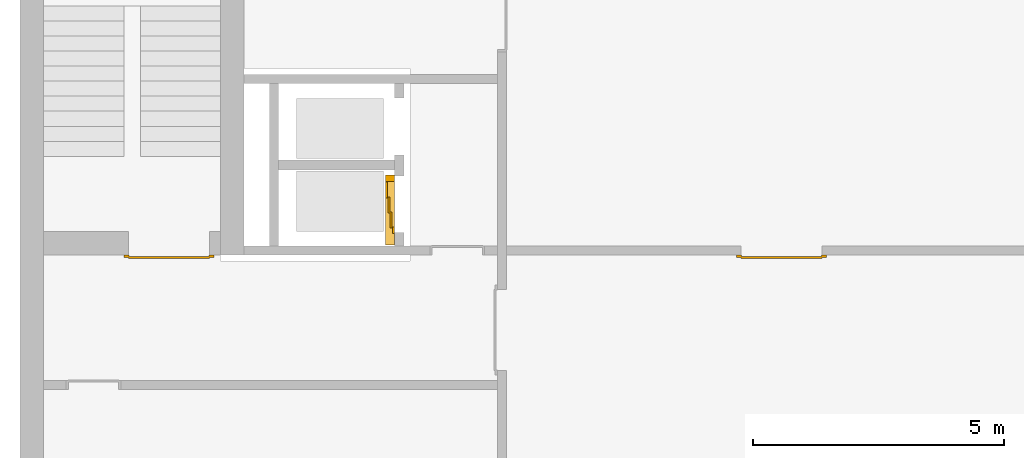
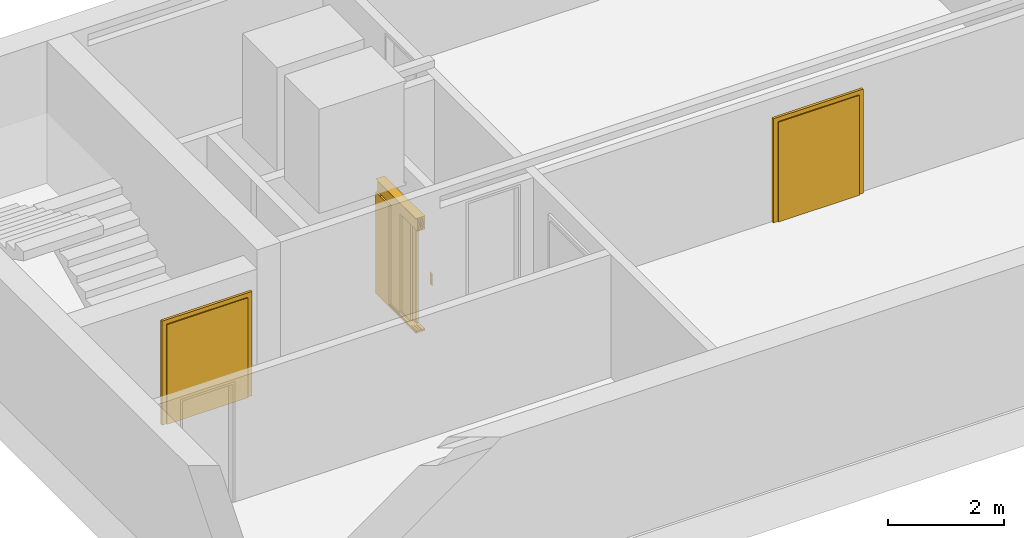
# One storey, part 4 of 5: 3 doors.
"""IFC4 building model written with IfcOpenShell, lengths in metres."""

import ifcopenshell
import ifcopenshell.guid

model = None  # the IFC model being written
_history = None  # IfcOwnerHistory: only IFC2X3 demands one
_inside = {}  # id of a spatial element -> (the spatial element, [elements in it])
_under = {}  # id of a project, library or spatial element -> (it, [spatial elements below it])
_declared = {}  # id of a project -> (the project, [libraries it declares])
_typed = {}  # id of a type object -> (the type object, [elements of that type])
_made_of = {}  # id of a material, layer set ... -> (it, [elements and type objects made of it])


def new_model(schema):
    """Start an empty IFC model of exactly this schema.

    Asked for "IFC4X3", IfcOpenShell would pick the latest addendum, in which some entities
    have other attributes; the version numbers below select the first issue.
    IFC2X3 requires an IfcOwnerHistory on every rooted entity: one is made here for all.
    """
    global model, _history
    if schema == "IFC4X3":
        model = ifcopenshell.file(schema_version=(4, 3, 0, 0))
    else:
        model = ifcopenshell.file(schema=schema)
    _inside.clear()
    _under.clear()
    _declared.clear()
    _typed.clear()
    _made_of.clear()
    _history = None
    if model.schema == "IFC2X3":
        org = make("IfcOrganization", Name="unknown")
        user = make(
            "IfcPersonAndOrganization",
            ThePerson=make("IfcPerson", FamilyName="unknown"),
            TheOrganization=org,
        )
        app = make(
            "IfcApplication",
            ApplicationDeveloper=org,
            Version="unknown",
            ApplicationFullName="unknown",
            ApplicationIdentifier="unknown",
        )
        _history = make(
            "IfcOwnerHistory",
            OwningUser=user,
            OwningApplication=app,
            ChangeAction="ADDED",
            CreationDate=0,
        )
    return model


def make(cls, **values):
    """One entity of the class cls with the attributes given. An attribute that is None is left unset."""
    return model.create_entity(
        cls, **{name: value for name, value in values.items() if value is not None}
    )


def entity(cls, *values):
    """Any entity or typed value of the class cls, its attributes in the order of the schema. None: left unset."""
    e = model.create_entity(cls)
    for i, value in enumerate(values):
        if value is not None:
            e[i] = value
    return e


def rooted(cls, **values):
    """An entity with a GlobalId (a new one), such as an element, a storey or a relation."""
    return make(cls, GlobalId=ifcopenshell.guid.new(), OwnerHistory=_history, **values)


def si_unit(unit_type, name, prefix=None):
    """IfcSIUnit, for example si_unit("LENGTHUNIT", "METRE", prefix="MILLI")."""
    return make("IfcSIUnit", UnitType=unit_type, Prefix=prefix, Name=name)


def converted_unit(unit_type, name, factor, base, dimensions=None, offset=None):
    """IfcConversionBasedUnit, such as the inch: factor (a typed value) times the base unit."""
    return make(
        "IfcConversionBasedUnit"
        if offset is None
        else "IfcConversionBasedUnitWithOffset",
        ConversionOffset=offset,
        Dimensions=None
        if dimensions is None
        else entity("IfcDimensionalExponents", *dimensions),
        UnitType=unit_type,
        Name=name,
        ConversionFactor=make(
            "IfcMeasureWithUnit", ValueComponent=factor, UnitComponent=base
        ),
    )


def derived_unit(unit_type, elements):
    """IfcDerivedUnit: a product of units, each with its exponent."""
    return make(
        "IfcDerivedUnit",
        Elements=[
            make("IfcDerivedUnitElement", Unit=unit, Exponent=power)
            for unit, power in elements
        ],
        UnitType=unit_type,
    )


def assignment(units):
    """IfcUnitAssignment: the units of a project."""
    return None if units is None else make("IfcUnitAssignment", Units=units)


def point(xyz):
    """IfcCartesianPoint."""
    return None if xyz is None else make("IfcCartesianPoint", Coordinates=xyz)


def direction(xyz):
    """IfcDirection."""
    return None if xyz is None else make("IfcDirection", DirectionRatios=xyz)


def frame(location, z_axis=None, x_axis=None):
    """IfcAxis2Placement3D, a coordinate frame: its origin and axes. An axis left out is left unset."""
    return make(
        "IfcAxis2Placement3D",
        Location=point(location),
        Axis=direction(z_axis),
        RefDirection=direction(x_axis),
    )


def origin_with_axes():
    """The frame at (0, 0, 0) with the z axis (0, 0, 1) and the x axis (1, 0, 0) written out."""
    return frame((0.0, 0.0, 0.0), z_axis=(0.0, 0.0, 1.0), x_axis=(1.0, 0.0, 0.0))


def place(relative_to, where):
    """IfcLocalPlacement: puts the frame where relative to a parent placement (None: the world)."""
    return make(
        "IfcLocalPlacement", PlacementRelTo=relative_to, RelativePlacement=where
    )


def context(
    kind, dimensions, precision=None, world=None, true_north=None, identifier=None
):
    """IfcGeometricRepresentationContext, for example the 3D "Model" context."""
    return make(
        "IfcGeometricRepresentationContext",
        ContextIdentifier=identifier,
        ContextType=kind,
        CoordinateSpaceDimension=dimensions,
        Precision=precision,
        WorldCoordinateSystem=world,
        TrueNorth=true_north,
    )


def subcontext(parent, identifier, kind, view, scale=None):
    """IfcGeometricRepresentationSubContext, for example "Body" below "Model"."""
    return make(
        "IfcGeometricRepresentationSubContext",
        ContextIdentifier=identifier,
        ContextType=kind,
        ParentContext=parent,
        TargetScale=scale,
        TargetView=view,
    )


def project(units=None, contexts=None):
    """IfcProject with its units and contexts."""
    return rooted(
        "IfcProject",
        Name="project",
        RepresentationContexts=contexts,
        UnitsInContext=assignment(units),
    )


def spatial(cls, under=None, at=None, **own):
    """A site, building, storey or space (cls), placed at a placement, below another one or the project."""
    s = rooted(cls, ObjectPlacement=at, **own)
    if under is not None:
        _under.setdefault(under.id(), (under, []))[1].append(s)
    return s


def point_list(points):
    """IfcCartesianPointList2D or 3D."""
    cls = (
        "IfcCartesianPointList2D" if len(points[0]) == 2 else "IfcCartesianPointList3D"
    )
    return make(cls, CoordList=points)


def polygons(points, faces, closed=None, point_numbers=None):
    """IfcPolygonalFaceSet: a face is its outer loop, then its inner loops; points numbered from 1."""
    made = []
    for loops in faces:
        if len(loops) == 1:
            made.append(make("IfcIndexedPolygonalFace", CoordIndex=loops[0]))
        else:
            made.append(
                make(
                    "IfcIndexedPolygonalFaceWithVoids",
                    CoordIndex=loops[0],
                    InnerCoordIndices=loops[1:],
                )
            )
    return make(
        "IfcPolygonalFaceSet",
        Coordinates=point_list(points),
        Closed=closed,
        Faces=made,
        PnIndex=point_numbers,
    )


def shape(context_of_items, identifier, shape_type, items):
    """IfcShapeRepresentation: the items that make up one representation, for example the "Body"."""
    return make(
        "IfcShapeRepresentation",
        ContextOfItems=context_of_items,
        RepresentationIdentifier=identifier,
        RepresentationType=shape_type,
        Items=items,
    )


def source(mapping_origin, context_of_items, identifier, shape_type, items):
    """IfcRepresentationMap: a shape defined once, which mapped items show again and again."""
    return make(
        "IfcRepresentationMap",
        MappingOrigin=mapping_origin,
        MappedRepresentation=shape(context_of_items, identifier, shape_type, items),
    )


def transform(
    local_origin,
    x_axis=None,
    y_axis=None,
    z_axis=None,
    scale=None,
    scale2=None,
    scale3=None,
    uniform=True,
):
    """IfcCartesianTransformationOperator3D, or its non-uniform kind. x_axis, y_axis, z_axis: its Axis1, 2, 3."""
    if uniform:
        return make(
            "IfcCartesianTransformationOperator3D",
            Axis1=direction(x_axis),
            Axis2=direction(y_axis),
            LocalOrigin=point(local_origin),
            Scale=scale,
            Axis3=direction(z_axis),
        )
    return make(
        "IfcCartesianTransformationOperator3DnonUniform",
        Axis1=direction(x_axis),
        Axis2=direction(y_axis),
        LocalOrigin=point(local_origin),
        Scale=scale,
        Axis3=direction(z_axis),
        Scale2=scale2,
        Scale3=scale3,
    )


def mapped(mapping_source, mapping_target):
    """IfcMappedItem: shows the shape of a source again, moved by a transform."""
    return make(
        "IfcMappedItem", MappingSource=mapping_source, MappingTarget=mapping_target
    )


def made_of(thing, what):
    """Note that an element or type object is made of a material, layer set ...; save() writes the relation."""
    if what is not None:
        _made_of.setdefault(what.id(), (what, []))[1].append(thing)
    return thing


def type_object(cls, material=None, **own):
    """A type object (cls), such as IfcWallType, which elements share."""
    return made_of(rooted(cls, **own), material)


def element(
    cls,
    number,
    at=None,
    inside=None,
    cuts=None,
    type_object=None,
    material=None,
    context=None,
    identifier="Body",
    shape_type=None,
    held_by="IfcProductDefinitionShape",
    body=None,
    shapes=None,
    **own,
):
    """One element of the class cls, such as IfcWall. Its Tag is "e" and its number.

    at: its placement. inside: the storey or other place that contains it. cuts: it is an
    opening in that element (IfcRelVoidsElement). A single representation is given by context,
    identifier, shape_type and body (its items); several are given by shapes. held_by: the class
    of the entity that holds the representations. save() writes the other relations.
    """
    e = rooted(cls, Tag="e%d" % number, ObjectPlacement=at, **own)
    if body is not None:
        shapes = [shape(context, identifier, shape_type, body)]
    if shapes is not None:
        e.Representation = make(held_by, Representations=shapes)
    if inside is not None:
        _inside.setdefault(inside.id(), (inside, []))[1].append(e)
    if cuts is not None:
        rooted(
            "IfcRelVoidsElement", RelatingBuildingElement=cuts, RelatedOpeningElement=e
        )
    if type_object is not None:
        _typed.setdefault(type_object.id(), (type_object, []))[1].append(e)
    return made_of(e, material)


def aggregate(whole, parts):
    """IfcRelAggregates: a whole, such as a stair, and the parts it consists of."""
    return rooted("IfcRelAggregates", RelatingObject=whole, RelatedObjects=parts)


def save(model, path):
    """Write the relations noted so far, then the file.

    IfcRelAggregates (storeys below a building ...), IfcRelContainedInSpatialStructure (elements
    in a storey), IfcRelDefinesByType, IfcRelAssociatesMaterial and IfcRelDeclares: one each for
    every whole, place, type object, material and project.
    """
    for whole, parts in _under.values():
        aggregate(whole, parts)
    for where, things in _inside.values():
        rooted(
            "IfcRelContainedInSpatialStructure",
            RelatedElements=things,
            RelatingStructure=where,
        )
    for kind, things in _typed.values():
        rooted("IfcRelDefinesByType", RelatedObjects=things, RelatingType=kind)
    for what, things in _made_of.values():
        rooted("IfcRelAssociatesMaterial", RelatedObjects=things, RelatingMaterial=what)
    for by, libraries in _declared.values():
        rooted("IfcRelDeclares", RelatingContext=by, RelatedDefinitions=libraries)
    model.write(path)


model = new_model("IFC4")

# Units and contexts
model_context = context("Model", 3, precision=1e-05, world=origin_with_axes(), true_north=direction((0.0, 1.0)))
body_context = subcontext(model_context, "Body", "Model", "MODEL_VIEW")
ifc_project = project(units=[si_unit("LENGTHUNIT", "METRE"), si_unit("AREAUNIT", "SQUARE_METRE"), si_unit("VOLUMEUNIT", "CUBIC_METRE"), converted_unit("PLANEANGLEUNIT", "DEGREE", entity("IfcPlaneAngleMeasure", 0.0174532925199433), si_unit("PLANEANGLEUNIT", "RADIAN"), dimensions=[0, 0, 0, 0, 0, 0, 0]), converted_unit("TIMEUNIT", "Year", entity("IfcTimeMeasure", 31557600.0), si_unit("TIMEUNIT", "SECOND"), dimensions=[0, 0, 1, 0, 0, 0, 0]), si_unit("MASSUNIT", "GRAM", prefix="KILO"), si_unit("THERMODYNAMICTEMPERATUREUNIT", "DEGREE_CELSIUS"), si_unit("LUMINOUSINTENSITYUNIT", "LUMEN"), si_unit("ENERGYUNIT", "JOULE", prefix="MEGA"), derived_unit("THERMALCONDUCTANCEUNIT", [(si_unit("POWERUNIT", "WATT"), 1), (si_unit("LENGTHUNIT", "METRE"), -1), (si_unit("THERMODYNAMICTEMPERATUREUNIT", "KELVIN"), -1)]), derived_unit("SPECIFICHEATCAPACITYUNIT", [(si_unit("ENERGYUNIT", "JOULE"), 1), (si_unit("MASSUNIT", "GRAM", prefix="KILO"), -1), (si_unit("THERMODYNAMICTEMPERATUREUNIT", "KELVIN"), -1)]), derived_unit("MASSDENSITYUNIT", [(si_unit("MASSUNIT", "GRAM", prefix="KILO"), 1), (si_unit("VOLUMEUNIT", "CUBIC_METRE"), -1)])], contexts=[model_context])

# Site, building, storey
site_placement = place(None, origin_with_axes())
site = spatial("IfcSite", under=ifc_project, at=site_placement, CompositionType="ELEMENT")
building_placement = place(site_placement, origin_with_axes())
building = spatial("IfcBuilding", under=site, at=building_placement, CompositionType="ELEMENT")
storey_placement = place(building_placement, frame((0.0, 0.0, -3.0), z_axis=(0.0, 0.0, 1.0), x_axis=(1.0, 0.0, 0.0)))
storey = spatial("IfcBuildingStorey", under=building, at=storey_placement, Name="UG", CompositionType="ELEMENT", Elevation=-3.0)

# Doors
door_type_1 = type_object("IfcDoorType", OperationType="DOUBLE_DOOR_SINGLE_SWING", PredefinedType="DOOR")
shared_shape_1 = source(origin_with_axes(), body_context, "Body", "Tessellation", [
    polygons([(-0.9000000000000001, 0.0, 0.0), (-0.9000000000000001, 0.0, 2.2), (-0.9000000000000001, 0.03, 2.2), (-0.9000000000000001, 0.03, 0.0), (-0.8000000000000002, 0.0, 0.0), (-0.8000000000000002, 0.0, 2.1), (-0.1101, 0.0, 2.1), (-0.0001, 0.0, 2.1), (0.8000000000000002, 0.0, 2.1), (0.8000000000000002, 0.0, 0.0), (0.9000000000000001, 0.0, 0.0), (0.9000000000000001, 0.0, 2.2), (0.9000000000000001, 0.03, 2.2), (0.9000000000000001, 0.03, 0.0), (0.8000000000000002, 0.03, 0.0), (0.8000000000000002, 0.03, 2.1), (-0.0001, 0.03, 2.1), (-0.1101, 0.03, 2.1), (-0.8000000000000002, 0.03, 2.1), (-0.8000000000000002, 0.03, 0.0)], [[[1, 2, 3, 4]], [[1, 5, 6, 7, 8, 9, 10, 11, 12, 2]], [[2, 12, 13, 3]], [[4, 3, 13, 14, 15, 16, 17, 18, 19, 20]], [[5, 1, 4, 20]], [[6, 5, 20, 19]], [[7, 6, 19, 18]], [[8, 7, 18, 17]], [[9, 8, 17, 16]], [[10, 9, 16, 15]], [[11, 10, 15, 14]], [[12, 11, 14, 13]]], closed=True),
    polygons([(-0.9000000000000001, 0.03, 0.0), (-0.9000000000000001, 0.03, 2.2), (-0.9000000000000001, 0.05, 2.2), (-0.9000000000000001, 0.05, 0.0), (-0.8100000000000002, 0.03, 0.0), (-0.8100000000000002, 0.03, 2.11), (-0.1001, 0.03, 2.11), (-0.0101, 0.03, 2.11), (0.8100000000000002, 0.03, 2.11), (0.8100000000000002, 0.03, 0.0), (0.9000000000000001, 0.03, 0.0), (0.9000000000000001, 0.03, 2.2), (0.9000000000000001, 0.05, 2.2), (0.9000000000000001, 0.05, 0.0), (0.8100000000000002, 0.05, 0.0), (0.8100000000000002, 0.05, 2.11), (-0.0101, 0.05, 2.11), (-0.1001, 0.05, 2.11), (-0.8100000000000002, 0.05, 2.11), (-0.8100000000000002, 0.05, 0.0)], [[[1, 2, 3, 4]], [[1, 5, 6, 7, 8, 9, 10, 11, 12, 2]], [[2, 12, 13, 3]], [[4, 3, 13, 14, 15, 16, 17, 18, 19, 20]], [[5, 1, 4, 20]], [[6, 5, 20, 19]], [[7, 6, 19, 18]], [[8, 7, 18, 17]], [[9, 8, 17, 16]], [[10, 9, 16, 15]], [[11, 10, 15, 14]], [[12, 11, 14, 13]]], closed=True),
    polygons([(-0.81, 0.07, 0.0), (-0.81, 0.07, 2.11), (-0.0004999999999999449, 0.07, 2.11), (-0.0004999999999999449, 0.07, 0.0), (-0.81, 0.03000000000000001, 0.0), (-0.81, 0.03000000000000001, 2.11), (-0.0004999999999999449, 0.03000000000000001, 2.11), (-0.0004999999999999449, 0.03000000000000001, 0.0)], [[[1, 2, 3, 4]], [[1, 5, 6, 2]], [[2, 6, 7, 3]], [[3, 7, 8, 4]], [[4, 8, 5, 1]], [[8, 7, 6, 5]]], closed=True),
    polygons([(0.81, 0.07, 0.0), (0.0004999999999999449, 0.07, 0.0), (0.0004999999999999449, 0.07, 2.11), (0.81, 0.07, 2.11), (0.81, 0.03000000000000001, 0.0), (0.0004999999999999449, 0.03000000000000001, 0.0), (0.0004999999999999449, 0.03000000000000001, 2.11), (0.81, 0.03000000000000001, 2.11)], [[[1, 2, 3, 4]], [[2, 1, 5, 6]], [[3, 2, 6, 7]], [[4, 3, 7, 8]], [[1, 4, 8, 5]], [[6, 5, 8, 7]]], closed=True),
])
door_1_placement = place(storey_placement, frame((39.96865764284701, 7.054999945467553, 0.0), z_axis=(0.0, 0.0, 1.0), x_axis=(-1.0, 0.0, 0.0)))
element("IfcDoor", 1, at=door_1_placement, inside=storey, type_object=door_type_1, OverallHeight=2.11, OverallWidth=1.62, PredefinedType="DOOR", context=body_context, shape_type="MappedRepresentation", body=[
    mapped(shared_shape_1, transform((0.7999999999999972, 0.0, 0.0))),
])
shared_shape_2 = source(origin_with_axes(), body_context, "Body", "Tessellation", [
    polygons([(-0.9000000000000001, 0.0, 0.0), (-0.9000000000000001, 0.0, 2.2), (-0.9000000000000001, 0.03, 2.2), (-0.9000000000000001, 0.03, 0.0), (-0.8000000000000002, 0.0, 0.0), (-0.8000000000000002, 0.0, 2.1), (-0.1101, 0.0, 2.1), (-0.0001, 0.0, 2.1), (0.8000000000000002, 0.0, 2.1), (0.8000000000000002, 0.0, 0.0), (0.9000000000000001, 0.0, 0.0), (0.9000000000000001, 0.0, 2.2), (0.9000000000000001, 0.03, 2.2), (0.9000000000000001, 0.03, 0.0), (0.8000000000000002, 0.03, 0.0), (0.8000000000000002, 0.03, 2.1), (-0.0001, 0.03, 2.1), (-0.1101, 0.03, 2.1), (-0.8000000000000002, 0.03, 2.1), (-0.8000000000000002, 0.03, 0.0)], [[[1, 2, 3, 4]], [[1, 5, 6, 7, 8, 9, 10, 11, 12, 2]], [[2, 12, 13, 3]], [[4, 3, 13, 14, 15, 16, 17, 18, 19, 20]], [[5, 1, 4, 20]], [[6, 5, 20, 19]], [[7, 6, 19, 18]], [[8, 7, 18, 17]], [[9, 8, 17, 16]], [[10, 9, 16, 15]], [[11, 10, 15, 14]], [[12, 11, 14, 13]]], closed=True),
    polygons([(-0.9000000000000001, 0.03, 0.0), (-0.9000000000000001, 0.03, 2.2), (-0.9000000000000001, 0.05, 2.2), (-0.9000000000000001, 0.05, 0.0), (-0.8100000000000002, 0.03, 0.0), (-0.8100000000000002, 0.03, 2.11), (-0.1001, 0.03, 2.11), (-0.0101, 0.03, 2.11), (0.8100000000000002, 0.03, 2.11), (0.8100000000000002, 0.03, 0.0), (0.9000000000000001, 0.03, 0.0), (0.9000000000000001, 0.03, 2.2), (0.9000000000000001, 0.05, 2.2), (0.9000000000000001, 0.05, 0.0), (0.8100000000000002, 0.05, 0.0), (0.8100000000000002, 0.05, 2.11), (-0.0101, 0.05, 2.11), (-0.1001, 0.05, 2.11), (-0.8100000000000002, 0.05, 2.11), (-0.8100000000000002, 0.05, 0.0)], [[[1, 2, 3, 4]], [[1, 5, 6, 7, 8, 9, 10, 11, 12, 2]], [[2, 12, 13, 3]], [[4, 3, 13, 14, 15, 16, 17, 18, 19, 20]], [[5, 1, 4, 20]], [[6, 5, 20, 19]], [[7, 6, 19, 18]], [[8, 7, 18, 17]], [[9, 8, 17, 16]], [[10, 9, 16, 15]], [[11, 10, 15, 14]], [[12, 11, 14, 13]]], closed=True),
    polygons([(-0.81, 0.07, 0.0), (-0.81, 0.07, 2.11), (-0.0004999999999999449, 0.07, 2.11), (-0.0004999999999999449, 0.07, 0.0), (-0.81, 0.03000000000000001, 0.0), (-0.81, 0.03000000000000001, 2.11), (-0.0004999999999999449, 0.03000000000000001, 2.11), (-0.0004999999999999449, 0.03000000000000001, 0.0)], [[[1, 2, 3, 4]], [[1, 5, 6, 2]], [[2, 6, 7, 3]], [[3, 7, 8, 4]], [[4, 8, 5, 1]], [[8, 7, 6, 5]]], closed=True),
    polygons([(0.81, 0.07, 0.0), (0.0004999999999999449, 0.07, 0.0), (0.0004999999999999449, 0.07, 2.11), (0.81, 0.07, 2.11), (0.81, 0.03000000000000001, 0.0), (0.0004999999999999449, 0.03000000000000001, 0.0), (0.0004999999999999449, 0.03000000000000001, 2.11), (0.81, 0.03000000000000001, 2.11)], [[[1, 2, 3, 4]], [[2, 1, 5, 6]], [[3, 2, 6, 7]], [[4, 3, 7, 8]], [[1, 4, 8, 5]], [[6, 5, 8, 7]]], closed=True),
])
door_2_placement = place(storey_placement, frame((27.75800000000001, 7.054999945467554, 0.0), z_axis=(0.0, 0.0, 1.0), x_axis=(-1.0, 0.0, 0.0)))
element("IfcDoor", 2, at=door_2_placement, inside=storey, type_object=door_type_1, OverallHeight=2.11, OverallWidth=1.62, PredefinedType="DOOR", context=body_context, shape_type="MappedRepresentation", body=[
    mapped(shared_shape_2, transform((0.8000000000000007, 0.0, 0.0))),
])
door_type_2 = type_object("IfcDoorType", Name="27", OperationType="DOUBLE_DOOR_SLIDING", PredefinedType="DOOR")
shared_shape_3 = source(origin_with_axes(), body_context, "Body", "Tessellation", [
    polygons([(-0.8083333333333336, 0.135, 2.1), (-0.8083333333333336, 0.135, 2.138), (0.585, 0.1349999999999999, 2.138), (0.585, 0.1349999999999999, 2.1), (-0.8083333333333336, 0.0, 2.1), (-0.8083333333333336, 0.0, 2.38), (-0.8083333333333336, 0.18, 2.38), (-0.8083333333333336, 0.18, 2.377), (-0.8083333333333336, 0.003, 2.377), (-0.8083333333333336, 0.003, 2.103), (-0.8083333333333336, 0.132, 2.103), (-0.8083333333333336, 0.132, 2.138), (0.585, 0.1319999999999999, 2.138), (0.585, 0.1319999999999999, 2.103), (0.585, 0.002999999999999915, 2.103), (0.585, 0.002999999999999915, 2.377), (0.585, 0.1799999999999999, 2.377), (0.585, 0.1799999999999999, 2.38), (0.585, 0.0, 2.38), (0.585, 0.0, 2.1)], [[[1, 2, 3, 4]], [[1, 5, 6, 7, 8, 9, 10, 11, 12, 2]], [[2, 12, 13, 3]], [[4, 3, 13, 14, 15, 16, 17, 18, 19, 20]], [[5, 1, 4, 20]], [[6, 5, 20, 19]], [[7, 6, 19, 18]], [[8, 7, 18, 17]], [[9, 8, 17, 16]], [[10, 9, 16, 15]], [[11, 10, 15, 14]], [[12, 11, 14, 13]]], closed=True),
    polygons([(-0.8083333333333336, 0.05, 2.103), (-0.8083333333333336, 0.05499999999999999, 2.103), (0.585, 0.05499999999999991, 2.103), (0.585, 0.04999999999999991, 2.103), (-0.8083333333333336, 0.05, 2.34), (-0.8083333333333336, 0.05499999999999999, 2.34), (0.585, 0.05499999999999991, 2.34), (0.585, 0.04999999999999991, 2.34)], [[[1, 2, 3, 4]], [[1, 5, 6, 2]], [[2, 6, 7, 3]], [[4, 3, 7, 8]], [[5, 1, 4, 8]], [[6, 5, 8, 7]]], closed=True),
    polygons([(-0.8083333333333336, 0.05, 2.33), (-0.8083333333333336, 0.03999999999999999, 2.33), (0.585, 0.03999999999999991, 2.33), (0.585, 0.04999999999999991, 2.33), (-0.8083333333333336, 0.05, 2.27), (-0.8083333333333336, 0.03999999999999999, 2.27), (0.585, 0.03999999999999991, 2.27), (0.585, 0.04999999999999991, 2.27)], [[[1, 2, 3, 4]], [[1, 5, 6, 2]], [[2, 6, 7, 3]], [[4, 3, 7, 8]], [[5, 1, 4, 8]], [[6, 5, 8, 7]]], closed=True),
    polygons([(-0.8083333333333336, 0.05, 2.2), (-0.8083333333333336, 0.03999999999999999, 2.2), (0.585, 0.03999999999999991, 2.2), (0.585, 0.04999999999999991, 2.2), (-0.8083333333333336, 0.05, 2.16), (-0.8083333333333336, 0.03999999999999999, 2.16), (0.585, 0.03999999999999991, 2.16), (0.585, 0.04999999999999991, 2.16)], [[[1, 2, 3, 4]], [[1, 5, 6, 2]], [[2, 6, 7, 3]], [[4, 3, 7, 8]], [[5, 1, 4, 8]], [[6, 5, 8, 7]]], closed=True),
    polygons([(-0.8083333333333336, 0.05, 2.27), (-0.8083333333333336, 0.03, 2.27), (0.585, 0.02999999999999991, 2.27), (0.585, 0.04999999999999991, 2.27), (-0.8083333333333336, 0.05, 2.2), (-0.8083333333333336, 0.03, 2.2), (0.585, 0.02999999999999991, 2.2), (0.585, 0.04999999999999991, 2.2)], [[[1, 2, 3, 4]], [[1, 5, 6, 2]], [[2, 6, 7, 3]], [[4, 3, 7, 8]], [[5, 1, 4, 8]], [[6, 5, 8, 7]]], closed=True),
    polygons([(-0.8083333333333336, 0.095, 2.103), (-0.8083333333333336, 0.1, 2.103), (0.585, 0.09999999999999992, 2.103), (0.585, 0.09499999999999992, 2.103), (-0.8083333333333336, 0.095, 2.34), (-0.8083333333333336, 0.1, 2.34), (0.585, 0.09999999999999992, 2.34), (0.585, 0.09499999999999992, 2.34)], [[[1, 2, 3, 4]], [[1, 5, 6, 2]], [[2, 6, 7, 3]], [[4, 3, 7, 8]], [[5, 1, 4, 8]], [[6, 5, 8, 7]]], closed=True),
    polygons([(-0.8083333333333336, 0.095, 2.33), (-0.8083333333333336, 0.085, 2.33), (0.585, 0.08499999999999991, 2.33), (0.585, 0.09499999999999992, 2.33), (-0.8083333333333336, 0.095, 2.27), (-0.8083333333333336, 0.085, 2.27), (0.585, 0.08499999999999991, 2.27), (0.585, 0.09499999999999992, 2.27)], [[[1, 2, 3, 4]], [[1, 5, 6, 2]], [[2, 6, 7, 3]], [[4, 3, 7, 8]], [[5, 1, 4, 8]], [[6, 5, 8, 7]]], closed=True),
    polygons([(-0.8083333333333336, 0.095, 2.2), (-0.8083333333333336, 0.085, 2.2), (0.585, 0.08499999999999991, 2.2), (0.585, 0.09499999999999992, 2.2), (-0.8083333333333336, 0.095, 2.16), (-0.8083333333333336, 0.085, 2.16), (0.585, 0.08499999999999991, 2.16), (0.585, 0.09499999999999992, 2.16)], [[[1, 2, 3, 4]], [[1, 5, 6, 2]], [[2, 6, 7, 3]], [[4, 3, 7, 8]], [[5, 1, 4, 8]], [[6, 5, 8, 7]]], closed=True),
    polygons([(-0.8083333333333336, 0.095, 2.27), (-0.8083333333333336, 0.075, 2.27), (0.585, 0.07499999999999991, 2.27), (0.585, 0.09499999999999992, 2.27), (-0.8083333333333336, 0.095, 2.2), (-0.8083333333333336, 0.075, 2.2), (0.585, 0.07499999999999991, 2.2), (0.585, 0.09499999999999992, 2.2)], [[[1, 2, 3, 4]], [[1, 5, 6, 2]], [[2, 6, 7, 3]], [[4, 3, 7, 8]], [[5, 1, 4, 8]], [[6, 5, 8, 7]]], closed=True),
    polygons([(-0.8083333333333336, 0.14, 2.103), (-0.8083333333333336, 0.145, 2.103), (0.585, 0.1449999999999999, 2.103), (0.585, 0.1399999999999999, 2.103), (-0.8083333333333336, 0.14, 2.34), (-0.8083333333333336, 0.145, 2.34), (0.585, 0.1449999999999999, 2.34), (0.585, 0.1399999999999999, 2.34)], [[[1, 2, 3, 4]], [[1, 5, 6, 2]], [[2, 6, 7, 3]], [[4, 3, 7, 8]], [[5, 1, 4, 8]], [[6, 5, 8, 7]]], closed=True),
    polygons([(-0.8083333333333336, 0.14, 2.33), (-0.8083333333333336, 0.13, 2.33), (0.585, 0.1299999999999999, 2.33), (0.585, 0.1399999999999999, 2.33), (-0.8083333333333336, 0.14, 2.27), (-0.8083333333333336, 0.13, 2.27), (0.585, 0.1299999999999999, 2.27), (0.585, 0.1399999999999999, 2.27)], [[[1, 2, 3, 4]], [[1, 5, 6, 2]], [[2, 6, 7, 3]], [[4, 3, 7, 8]], [[5, 1, 4, 8]], [[6, 5, 8, 7]]], closed=True),
    polygons([(-0.8083333333333336, 0.14, 2.2), (-0.8083333333333336, 0.13, 2.2), (0.585, 0.1299999999999999, 2.2), (0.585, 0.1399999999999999, 2.2), (-0.8083333333333336, 0.14, 2.16), (-0.8083333333333336, 0.13, 2.16), (0.585, 0.1299999999999999, 2.16), (0.585, 0.1399999999999999, 2.16)], [[[1, 2, 3, 4]], [[1, 5, 6, 2]], [[2, 6, 7, 3]], [[4, 3, 7, 8]], [[5, 1, 4, 8]], [[6, 5, 8, 7]]], closed=True),
    polygons([(-0.8083333333333336, 0.14, 2.27), (-0.8083333333333336, 0.12, 2.27), (0.585, 0.1199999999999999, 2.27), (0.585, 0.1399999999999999, 2.27), (-0.8083333333333336, 0.14, 2.2), (-0.8083333333333336, 0.12, 2.2), (0.585, 0.1199999999999999, 2.2), (0.585, 0.1399999999999999, 2.2)], [[[1, 2, 3, 4]], [[1, 5, 6, 2]], [[2, 6, 7, 3]], [[4, 3, 7, 8]], [[5, 1, 4, 8]], [[6, 5, 8, 7]]], closed=True),
    polygons([(-0.8083333333333336, 0.0, 0.0), (-0.8083333333333336, 0.0, -0.04), (0.585, 0.0, -0.04), (0.585, 0.0, 0.0), (-0.8083333333333336, 0.065, 0.0), (-0.8083333333333336, 0.065, -0.01), (-0.8083333333333336, 0.07500000000000001, -0.01), (-0.8083333333333336, 0.07500000000000001, 0.0), (-0.8083333333333336, 0.11, 0.0), (-0.8083333333333336, 0.11, -0.01), (-0.8083333333333336, 0.12, -0.01), (-0.8083333333333336, 0.12, 0.0), (-0.8083333333333336, 0.155, 0.0), (-0.8083333333333336, 0.155, -0.01), (-0.8083333333333336, 0.165, -0.01), (-0.8083333333333336, 0.165, 0.0), (-0.8083333333333336, 0.18, 0.0), (-0.8083333333333336, 0.18, -0.04), (0.585, 0.1799999999999999, -0.04), (0.585, 0.1799999999999999, 0.0), (0.585, 0.1649999999999999, 0.0), (0.585, 0.1649999999999999, -0.01), (0.585, 0.1549999999999999, -0.01), (0.585, 0.1549999999999999, 0.0), (0.585, 0.1199999999999999, 0.0), (0.585, 0.1199999999999999, -0.01), (0.585, 0.1099999999999999, -0.01), (0.585, 0.1099999999999999, 0.0), (0.585, 0.07499999999999993, 0.0), (0.585, 0.07499999999999993, -0.01), (0.585, 0.06499999999999992, -0.01), (0.585, 0.06499999999999992, 0.0)], [[[1, 2, 3, 4]], [[1, 5, 6, 7, 8, 9, 10, 11, 12, 13, 14, 15, 16, 17, 18, 2]], [[2, 18, 19, 3]], [[4, 3, 19, 20, 21, 22, 23, 24, 25, 26, 27, 28, 29, 30, 31, 32]], [[5, 1, 4, 32]], [[6, 5, 32, 31]], [[7, 6, 31, 30]], [[8, 7, 30, 29]], [[9, 8, 29, 28]], [[10, 9, 28, 27]], [[11, 10, 27, 26]], [[12, 11, 26, 25]], [[13, 12, 25, 24]], [[14, 13, 24, 23]], [[15, 14, 23, 22]], [[16, 15, 22, 21]], [[17, 16, 21, 20]], [[18, 17, 20, 19]]], closed=True),
    polygons([(-0.45, 0.0, 0.0), (-0.45, 0.045, 0.0), (-0.45, 0.04499999999999987, 2.1), (-0.45, 0.0, 2.1), (-0.585, 0.0, 0.0), (-0.585, 0.045, 0.0), (-0.585, 0.04499999999999987, 2.1), (-0.585, 0.0, 2.1)], [[[1, 2, 3, 4]], [[1, 5, 6, 2]], [[2, 6, 7, 3]], [[4, 3, 7, 8]], [[5, 1, 4, 8]], [[6, 5, 8, 7]]], closed=True),
    polygons([(0.585, 0.0, 0.0), (0.585, 0.18, 0.0), (0.585, 0.1799999999999999, 2.1), (0.585, 0.0, 2.1), (0.45, 0.0, 0.0), (0.45, 0.18, 0.0), (0.45, 0.1799999999999999, 2.1), (0.45, 0.0, 2.1)], [[[1, 2, 3, 4]], [[1, 5, 6, 2]], [[2, 6, 7, 3]], [[4, 3, 7, 8]], [[5, 1, 4, 8]], [[6, 5, 8, 7]]], closed=True),
    polygons([(-0.7450000000000002, -0.18, 0.8), (-0.6650000000000001, -0.18, 0.8), (-0.6650000000000001, -0.183, 0.8), (-0.7450000000000002, -0.183, 0.8), (-0.7450000000000002, -0.18, 1.06), (-0.6650000000000001, -0.18, 1.06), (-0.7350000000000002, -0.18, 1.03), (-0.7350000000000002, -0.18, 0.9400000000000001), (-0.6750000000000002, -0.18, 0.9400000000000001), (-0.6750000000000002, -0.18, 1.03), (-0.7150000000000002, -0.18, 0.8400000000000001), (-0.6950000000000002, -0.18, 0.8400000000000001), (-0.6950000000000002, -0.18, 0.8600000000000001), (-0.7150000000000002, -0.18, 0.8600000000000001), (-0.7150000000000002, -0.18, 0.88), (-0.6950000000000002, -0.18, 0.88), (-0.6950000000000002, -0.18, 0.9), (-0.7150000000000002, -0.18, 0.9), (-0.6650000000000001, -0.183, 1.06), (-0.7450000000000002, -0.183, 1.06), (-0.7350000000000002, -0.183, 1.03), (-0.6750000000000002, -0.183, 1.03), (-0.6750000000000002, -0.183, 0.9400000000000001), (-0.7350000000000002, -0.183, 0.9400000000000001), (-0.7150000000000002, -0.183, 0.8400000000000001), (-0.7150000000000002, -0.183, 0.8600000000000001), (-0.6950000000000002, -0.183, 0.8600000000000001), (-0.6950000000000002, -0.183, 0.8400000000000001), (-0.7150000000000002, -0.183, 0.88), (-0.7150000000000002, -0.183, 0.9), (-0.6950000000000002, -0.183, 0.9), (-0.6950000000000002, -0.183, 0.88)], [[[1, 2, 3, 4]], [[1, 5, 6, 2], [7, 8, 9, 10], [11, 12, 13, 14], [15, 16, 17, 18]], [[2, 6, 19, 3]], [[4, 3, 19, 20], [21, 22, 23, 24], [25, 26, 27, 28], [29, 30, 31, 32]], [[5, 1, 4, 20]], [[6, 5, 20, 19]], [[8, 7, 21, 24]], [[9, 8, 24, 23]], [[10, 9, 23, 22]], [[7, 10, 22, 21]], [[12, 11, 25, 28]], [[13, 12, 28, 27]], [[14, 13, 27, 26]], [[11, 14, 26, 25]], [[16, 15, 29, 32]], [[17, 16, 32, 31]], [[18, 17, 31, 30]], [[15, 18, 30, 29]]], closed=True),
    polygons([(-0.7350000000000002, -0.18, 0.9400000000000001), (-0.6750000000000002, -0.18, 0.9400000000000001), (-0.6750000000000002, -0.1825, 0.9400000000000001), (-0.7350000000000002, -0.1825, 0.9400000000000001), (-0.7350000000000002, -0.18, 1.03), (-0.6750000000000002, -0.18, 1.03), (-0.6750000000000002, -0.1825, 1.03), (-0.7350000000000002, -0.1825, 1.03)], [[[1, 2, 3, 4]], [[1, 5, 6, 2]], [[2, 6, 7, 3]], [[4, 3, 7, 8]], [[5, 1, 4, 8]], [[6, 5, 8, 7]]], closed=True),
    polygons([(-0.7210000000000002, -0.183, 1.005), (-0.7150000000000002, -0.183, 1.021), (-0.7090000000000002, -0.183, 1.005)], [[[1, 2, 3]]], closed=False),
    polygons([(-0.6950000000000002, -0.183, 1.005), (-0.7010000000000002, -0.183, 1.021), (-0.6890000000000002, -0.183, 1.021)], [[[1, 2, 3]]], closed=False),
    polygons([(-0.7077272727272729, -0.1835, 0.9820000000000001), (-0.7077272727272729, -0.1835, 0.9716363636363637), (-0.7090909090909092, -0.1835, 0.9702727272727274), (-0.7104545454545456, -0.1835, 0.9716363636363637), (-0.7104545454545456, -0.1835, 0.9820000000000001), (-0.7090909090909092, -0.1835, 0.9833636363636364)], [[[1, 2, 3, 4, 5, 6]]], closed=False),
    polygons([(-0.7077272727272729, -0.1835, 0.9683636363636364), (-0.7077272727272729, -0.1835, 0.9580000000000001), (-0.7090909090909092, -0.1835, 0.9566363636363637), (-0.7104545454545456, -0.1835, 0.9580000000000001), (-0.7104545454545456, -0.1835, 0.9683636363636364), (-0.7090909090909092, -0.1835, 0.9697272727272728)], [[[1, 2, 3, 4, 5, 6]]], closed=False),
    polygons([(-0.688909090909091, -0.1835, 0.9822727272727274), (-0.6992727272727274, -0.1835, 0.9822727272727274), (-0.7006363636363637, -0.1835, 0.9836363636363638), (-0.6992727272727274, -0.1835, 0.9850000000000001), (-0.688909090909091, -0.1835, 0.9850000000000001), (-0.6875454545454547, -0.1835, 0.9836363636363638)], [[[1, 2, 3, 4, 5, 6]]], closed=False),
    polygons([(-0.6859090909090911, -0.1835, 0.9820000000000001), (-0.6859090909090911, -0.1835, 0.9716363636363637), (-0.6872727272727275, -0.1835, 0.9702727272727274), (-0.6886363636363638, -0.1835, 0.9716363636363637), (-0.6886363636363638, -0.1835, 0.9820000000000001), (-0.6872727272727275, -0.1835, 0.9833636363636364)], [[[1, 2, 3, 4, 5, 6]]], closed=False),
    polygons([(-0.6889090909090911, -0.1835, 0.9686363636363637), (-0.6992727272727275, -0.1835, 0.9686363636363637), (-0.7006363636363638, -0.1835, 0.9700000000000001), (-0.6992727272727275, -0.1835, 0.9713636363636364), (-0.6889090909090911, -0.1835, 0.9713636363636364), (-0.6875454545454548, -0.1835, 0.9700000000000001)], [[[1, 2, 3, 4, 5, 6]]], closed=False),
    polygons([(-0.6995454545454548, -0.1835, 0.9683636363636364), (-0.6995454545454548, -0.1835, 0.9580000000000001), (-0.7009090909090911, -0.1835, 0.9566363636363637), (-0.7022727272727275, -0.1835, 0.9580000000000001), (-0.7022727272727275, -0.1835, 0.9683636363636364), (-0.7009090909090911, -0.1835, 0.9697272727272728)], [[[1, 2, 3, 4, 5, 6]]], closed=False),
    polygons([(-0.6889090909090911, -0.1835, 0.9550000000000001), (-0.6992727272727275, -0.1835, 0.9550000000000001), (-0.7006363636363638, -0.1835, 0.9563636363636364), (-0.6992727272727275, -0.1835, 0.9577272727272728), (-0.6889090909090911, -0.1835, 0.9577272727272728), (-0.6875454545454548, -0.1835, 0.9563636363636364)], [[[1, 2, 3, 4, 5, 6]]], closed=False),
    polygons([(-0.6950000000000002, -0.18, 0.8400000000000001), (-0.7150000000000002, -0.18, 0.8400000000000001), (-0.7150000000000002, -0.18, 0.8600000000000001), (-0.6950000000000002, -0.18, 0.8600000000000001), (-0.6949999999052288, -0.1815, 0.8399999996104838), (-0.7150000003895165, -0.1815, 0.8399999996104838), (-0.7150000003895165, -0.1815, 0.8600000000947715), (-0.6949999999052288, -0.1815, 0.8600000000947715), (-0.6964000003209712, -0.1829000004157424, 0.8414000000262262), (-0.7135999999737741, -0.1829000004157424, 0.8414000000262262), (-0.7135999999737741, -0.1829000004157424, 0.8585999996790291), (-0.6964000003209712, -0.1829000004157424, 0.8585999996790291)], [[[1, 2, 3, 4]], [[2, 1, 5, 6]], [[3, 2, 6, 7]], [[4, 3, 7, 8]], [[1, 4, 8, 5]], [[6, 5, 9, 10]], [[7, 6, 10, 11]], [[8, 7, 11, 12]], [[5, 8, 12, 9]], [[11, 10, 9, 12]]], closed=True),
    polygons([(-0.7000000000000002, -0.183, 0.8550000000000001), (-0.7050000000000002, -0.183, 0.8440000000000001), (-0.7100000000000002, -0.183, 0.8550000000000001)], [[[1, 2, 3]]], closed=False),
    polygons([(-0.6950000000000002, -0.18, 0.8800000000000001), (-0.7150000000000002, -0.18, 0.8800000000000001), (-0.7150000000000002, -0.18, 0.9000000000000001), (-0.6950000000000002, -0.18, 0.9000000000000001), (-0.6949999999052288, -0.1815, 0.8799999996104838), (-0.7150000003895165, -0.1815, 0.8799999996104838), (-0.7150000003895165, -0.1815, 0.9000000000947715), (-0.6949999999052288, -0.1815, 0.9000000000947715), (-0.6964000003209712, -0.1829000004157424, 0.8814000000262262), (-0.7135999999737741, -0.1829000004157424, 0.8814000000262262), (-0.7135999999737741, -0.1829000004157424, 0.8985999996790291), (-0.6964000003209712, -0.1829000004157424, 0.8985999996790291)], [[[1, 2, 3, 4]], [[2, 1, 5, 6]], [[3, 2, 6, 7]], [[4, 3, 7, 8]], [[1, 4, 8, 5]], [[6, 5, 9, 10]], [[7, 6, 10, 11]], [[8, 7, 11, 12]], [[5, 8, 12, 9]], [[11, 10, 9, 12]]], closed=True),
    polygons([(-0.7000000000000002, -0.183, 0.8850000000000001), (-0.7100000000000002, -0.183, 0.8850000000000001), (-0.7050000000000002, -0.183, 0.8960000000000001)], [[[1, 2, 3]]], closed=False),
    polygons([(0.1266666666666666, 0.14, 0.003), (0.1266666666666666, 0.18, 0.003), (0.445, 0.18, 0.003), (0.445, 0.14, 0.003), (0.1266666666666666, 0.14, 2.1), (0.1266666666666666, 0.18, 2.1), (0.445, 0.18, 2.1), (0.445, 0.14, 2.1)], [[[1, 2, 3, 4]], [[5, 6, 2, 1]], [[2, 6, 7, 3]], [[4, 3, 7, 8]], [[1, 4, 8, 5]], [[8, 7, 6, 5]]], closed=True),
    polygons([(-0.1716666666666667, 0.095, 0.003), (-0.1716666666666667, 0.135, 0.003), (0.1466666666666667, 0.135, 0.003), (0.1466666666666667, 0.09500000000000004, 0.003), (-0.1716666666666667, 0.095, 2.1), (-0.1716666666666667, 0.135, 2.1), (0.1466666666666667, 0.135, 2.1), (0.1466666666666667, 0.09500000000000004, 2.1)], [[[1, 2, 3, 4]], [[5, 6, 2, 1]], [[2, 6, 7, 3]], [[4, 3, 7, 8]], [[1, 4, 8, 5]], [[8, 7, 6, 5]]], closed=True),
    polygons([(-0.47, 0.05, 0.003), (-0.47, 0.09, 0.003), (-0.1516666666666667, 0.09000000000000004, 0.003), (-0.1516666666666667, 0.05000000000000004, 0.003), (-0.47, 0.05, 2.1), (-0.47, 0.09, 2.1), (-0.1516666666666667, 0.09000000000000004, 2.1), (-0.1516666666666667, 0.05000000000000004, 2.1)], [[[1, 2, 3, 4]], [[5, 6, 2, 1]], [[2, 6, 7, 3]], [[4, 3, 7, 8]], [[1, 4, 8, 5]], [[8, 7, 6, 5]]], closed=True),
])
door_3_placement = place(storey_placement, frame((31.63800000000001, 7.619999945467556, 0.0), z_axis=(0.0, 0.0, 1.0), x_axis=(0.0, 1.0, 0.0)))
element("IfcDoor", 3, at=door_3_placement, inside=storey, type_object=door_type_2, OverallHeight=2.25, OverallWidth=1.13, PredefinedType="DOOR", context=body_context, shape_type="MappedRepresentation", body=[
    mapped(shared_shape_3, transform((0.4500000000000011, 0.1799999999999997, 0.0))),
])

save(model, "model.ifc")
